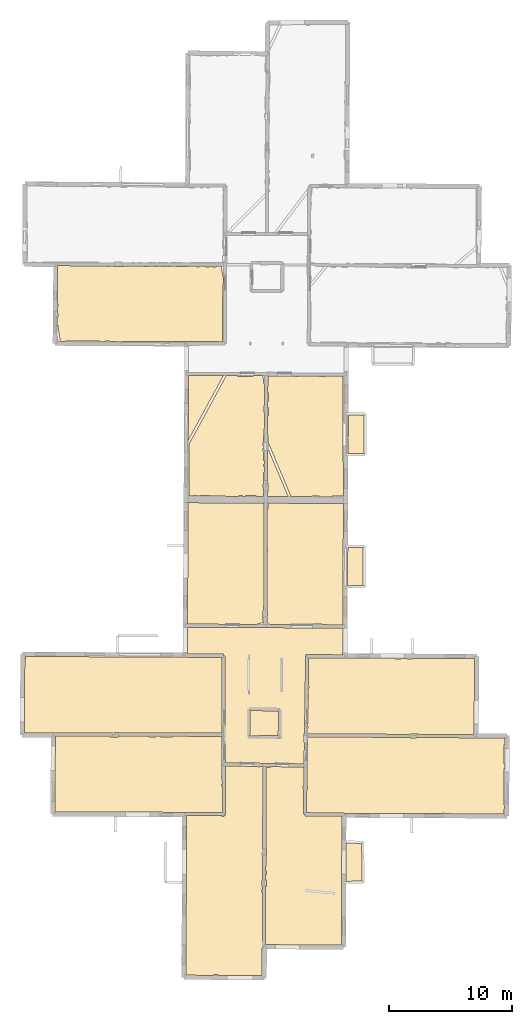
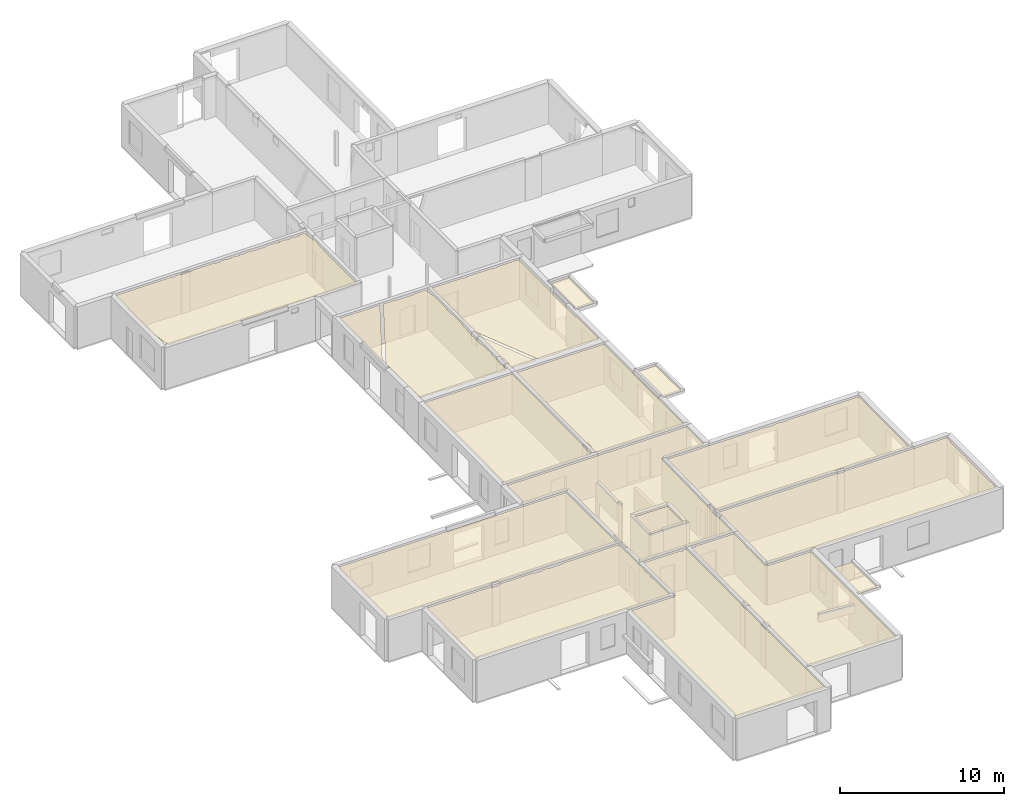
# One storey, part 12 of 15: 18 coverings.
"""IFC2X3 building model written with IfcOpenShell, lengths in metres."""

from ifc_helpers import new_model, entity, si_unit, converted_unit, derived_unit, direction, frame, origin, origin_with_axes, place, context, subcontext, project, spatial, polyline, outline, extrude, material, layer, layer_set, layer_usage, type_object, element, save


model = new_model("IFC2X3")

# Units and contexts
model_context = context("Model", 3, precision=1e-05, world=origin(), true_north=direction((0.0, 1.0)))
body_context = subcontext(model_context, "Body", "Model", "MODEL_VIEW")
ifc_project = project(units=[si_unit("LENGTHUNIT", "METRE"), si_unit("AREAUNIT", "SQUARE_METRE"), si_unit("VOLUMEUNIT", "CUBIC_METRE"), converted_unit("PLANEANGLEUNIT", "DEGREE", entity("IfcRatioMeasure", 0.0174532925199433), si_unit("PLANEANGLEUNIT", "RADIAN"), dimensions=[0, 0, 0, 0, 0, 0, 0]), si_unit("MASSUNIT", "GRAM", prefix="KILO"), derived_unit("MASSDENSITYUNIT", [(si_unit("MASSUNIT", "GRAM", prefix="KILO"), 1), (si_unit("LENGTHUNIT", "METRE"), -3)]), derived_unit("MOMENTOFINERTIAUNIT", [(si_unit("LENGTHUNIT", "METRE"), 4)]), si_unit("TIMEUNIT", "SECOND"), si_unit("FREQUENCYUNIT", "HERTZ"), si_unit("THERMODYNAMICTEMPERATUREUNIT", "DEGREE_CELSIUS"), derived_unit("THERMALTRANSMITTANCEUNIT", [(si_unit("MASSUNIT", "GRAM", prefix="KILO"), 1), (si_unit("THERMODYNAMICTEMPERATUREUNIT", "KELVIN"), -1), (si_unit("TIMEUNIT", "SECOND"), -3)]), derived_unit("VOLUMETRICFLOWRATEUNIT", [(si_unit("LENGTHUNIT", "METRE"), 3), (si_unit("TIMEUNIT", "SECOND"), -1)]), si_unit("ELECTRICCURRENTUNIT", "AMPERE"), si_unit("ELECTRICVOLTAGEUNIT", "VOLT"), si_unit("POWERUNIT", "WATT"), si_unit("FORCEUNIT", "NEWTON", prefix="KILO"), si_unit("ILLUMINANCEUNIT", "LUX"), si_unit("LUMINOUSFLUXUNIT", "LUMEN"), si_unit("LUMINOUSINTENSITYUNIT", "CANDELA"), derived_unit("USERDEFINED", [(si_unit("MASSUNIT", "GRAM", prefix="KILO"), -1), (si_unit("LENGTHUNIT", "METRE"), -2), (si_unit("TIMEUNIT", "SECOND"), 3), (si_unit("LUMINOUSFLUXUNIT", "LUMEN"), 1)]), derived_unit("LINEARVELOCITYUNIT", [(si_unit("LENGTHUNIT", "METRE"), 1), (si_unit("TIMEUNIT", "SECOND"), -1)]), si_unit("PRESSUREUNIT", "PASCAL"), derived_unit("USERDEFINED", [(si_unit("LENGTHUNIT", "METRE"), -2), (si_unit("MASSUNIT", "GRAM", prefix="KILO"), 1), (si_unit("TIMEUNIT", "SECOND"), -2)]), derived_unit("LINEARFORCEUNIT", [(si_unit("MASSUNIT", "GRAM", prefix="KILO"), 1), (si_unit("LENGTHUNIT", "METRE"), 1), (si_unit("TIMEUNIT", "SECOND"), -2), (si_unit("LENGTHUNIT", "METRE"), -1)]), derived_unit("PLANARFORCEUNIT", [(si_unit("MASSUNIT", "GRAM", prefix="KILO"), 1), (si_unit("LENGTHUNIT", "METRE"), 1), (si_unit("TIMEUNIT", "SECOND"), -2), (si_unit("LENGTHUNIT", "METRE"), -2)])], contexts=[model_context])

# Site, building, storey
placement = place(None, origin())
site = spatial("IfcSite", under=ifc_project, at=placement, CompositionType="ELEMENT")
building = spatial("IfcBuilding", under=site, at=placement, CompositionType="ELEMENT")
storey_placement = place(placement, frame((0.0, 0.0, 2.3807327747345)))
storey = spatial("IfcBuildingStorey", under=building, at=storey_placement, Name="Level 2", CompositionType="ELEMENT", Elevation=2.3807327747345)

# Coverings
ifc_material = material(Name="Covering default")
ifc_layer_1 = layer(ifc_material, 0.02)
ifc_layer_set_1 = layer_set([ifc_layer_1], Name="Covering : 20mm")
ifc_layer_usage_1 = layer_usage(ifc_layer_set_1, "AXIS3", "POSITIVE", 0.0)
covering_type_1 = type_object("IfcCoveringType", Name="Covering : 20mm", PredefinedType="CEILING")
covering_1_placement = place(placement, frame((0.0, 0.0, 5.31589412689209)))
element("IfcCovering", 1, at=covering_1_placement, inside=storey, type_object=covering_type_1, material=ifc_layer_usage_1, Name="Covering : 20mm", ObjectType="Covering : 20mm", PredefinedType="CEILING", context=body_context, shape_type="SweptSolid", body=[
    extrude(outline(polyline([(-0.157829284667969, 12.9143705368042), (2.72134494781494, 12.9002017974854), (2.719069480896, 12.8498077392578), (2.87133312225342, 12.8429336547852), (2.87508678436279, 12.9260663986206), (2.875168800354, 12.9428291320801), (3.00084209442139, 12.9432487487793), (2.98748683929443, 16.9389305114746), (5.66581439971924, 16.9010639190674), (5.66572093963623, 16.8449096679688), (5.82572078704834, 16.8446426391602), (5.82581043243408, 16.8988018035889), (6.04655170440674, 16.895679473877), (6.01854801177979, 9.86431217193604), (5.96411037445068, 9.86440277099609), (5.96385860443115, 9.71440124511719), (6.01794910430908, 9.71431159973145), (6.00982570648193, 7.67432165145874), (5.95046520233154, 7.67441987991333), (5.94960117340088, 7.15442276000977), (6.0077543258667, 7.15432596206665), (6.00651836395264, 6.8443341255188), (5.94908618927002, 6.84442901611328), (5.94883632659912, 6.69442749023438), (6.00592136383057, 6.69433259963989), (5.98218250274658, -0.08222496509552), (2.38758563995361, -0.0655936598777771), (2.38767910003662, -0.0096588134765625), (2.03768062591553, -0.00907516479492188), (2.03758907318115, -0.0639742910861969), (-0.201565742492676, -0.0536142587661743), (-0.157829284667969, 12.9143705368042)])), origin_with_axes(), (0.0, 0.0, 1.0), 0.02),
])
ifc_layer_2 = layer(ifc_material, 0.02)
ifc_layer_set_2 = layer_set([ifc_layer_2], Name="Covering : 20mm")
ifc_layer_usage_2 = layer_usage(ifc_layer_set_2, "AXIS3", "POSITIVE", 0.0)
covering_type_2 = type_object("IfcCoveringType", Name="Covering : 20mm", PredefinedType="CEILING")
covering_2_placement = place(placement, frame((0.0, 0.0, 5.31589412689209)))
element("IfcCovering", 2, at=covering_2_placement, inside=storey, type_object=covering_type_2, material=ifc_layer_usage_2, Name="Covering : 20mm", ObjectType="Covering : 20mm", PredefinedType="CEILING", context=body_context, shape_type="SweptSolid", body=[
    extrude(outline(polyline([(6.267746925354, 7.15250205993652), (6.3204984664917, 7.15250110626221), (6.32050800323486, 7.6675009727478), (6.26979923248291, 7.66750192642212), (6.27169704437256, 8.14388656616211), (6.33124828338623, 8.1437873840332), (6.33166408538818, 8.3937873840332), (6.27269268035889, 8.39388561248779), (6.27779865264893, 9.67577838897705), (6.33376216888428, 9.67535495758057), (6.33772373199463, 10.2003402709961), (6.27988910675049, 10.200777053833), (6.30630779266357, 16.8338451385498), (6.6557035446167, 16.8332633972168), (6.65579319000244, 16.8870658874512), (9.38121700286865, 16.8485336303711), (9.35917568206787, 15.328763961792), (9.30320262908936, 15.328857421875), (9.30287075042725, 15.1288566589355), (9.35627460479736, 15.1287679672241), (9.32572078704834, 13.0219354629517), (9.45070552825928, 13.0201234817505), (9.44924068450928, 12.8951320648193), (12.4550046920776, 12.8598709106445), (12.4258432388306, 2.39830803871155), (6.24891948699951, 2.42507600784302), (6.267746925354, 7.15250205993652)])), origin_with_axes(), (0.0, 0.0, 1.0), 0.02),
])
ifc_layer_3 = layer(ifc_material, 0.02)
ifc_layer_set_3 = layer_set([ifc_layer_3], Name="Covering : 20mm")
ifc_layer_usage_3 = layer_usage(ifc_layer_set_3, "AXIS3", "POSITIVE", 0.0)
covering_type_3 = type_object("IfcCoveringType", Name="Covering : 20mm", PredefinedType="CEILING")
covering_3_placement = place(placement, frame((0.0, 0.0, 5.31589412689209)))
element("IfcCovering", 3, at=covering_3_placement, inside=storey, type_object=covering_type_3, material=ifc_layer_usage_3, Name="Covering : 20mm", ObjectType="Covering : 20mm", PredefinedType="CEILING", context=body_context, shape_type="SweptSolid", body=[
    extrude(outline(polyline([(12.8089418411255, 10.684494972229), (14.0668363571167, 10.6495876312256), (14.0813512802124, 7.58163404464722), (12.8002710342407, 7.57379484176636), (12.8089418411255, 10.684494972229)])), origin_with_axes(), (0.0, 0.0, 1.0), 0.02),
])
ifc_layer_4 = layer(ifc_material, 0.02)
ifc_layer_set_4 = layer_set([ifc_layer_4], Name="Covering : 20mm")
ifc_layer_usage_4 = layer_usage(ifc_layer_set_4, "AXIS3", "POSITIVE", 0.0)
covering_type_4 = type_object("IfcCoveringType", Name="Covering : 20mm", PredefinedType="CEILING")
covering_4_placement = place(placement, frame((0.0, 0.0, 5.31589412689209)))
element("IfcCovering", 4, at=covering_4_placement, inside=storey, type_object=covering_type_4, material=ifc_layer_usage_4, Name="Covering : 20mm", ObjectType="Covering : 20mm", PredefinedType="CEILING", context=body_context, shape_type="SweptSolid", body=[
    extrude(outline(polyline([(9.60571575164795, 15.0883522033691), (9.66280460357666, 15.0882568359375), (9.66310405731201, 15.2682571411133), (9.60832500457764, 15.2683486938477), (9.65799999237061, 18.6934967041016), (9.6602201461792, 18.693452835083), (9.67202663421631, 19.3019237518311), (17.992317199707, 19.253267288208), (17.9925689697266, 19.1920928955078), (18.4975624084473, 19.194185256958), (18.4973297119141, 19.2503147125244), (23.794002532959, 19.2193412780762), (25.696964263916, 19.2175998687744), (25.6942901611328, 18.6815986633301), (25.6388053894043, 18.6816921234131), (25.6361618041992, 17.0916938781738), (25.6863632202148, 17.091609954834), (25.6846160888672, 16.7414112091064), (25.6255798339844, 16.7417087554932), (25.610652923584, 13.7817287445068), (25.6698532104492, 13.7814302444458), (25.6682586669922, 13.4616346359253), (25.6101226806641, 13.4617309570312), (25.6094207763672, 13.0385904312134), (20.8094482421875, 13.0603847503662), (20.8095474243164, 13.1197128295898), (20.6495475769043, 13.1199798583984), (20.6494483947754, 13.061110496521), (12.6366930007935, 13.0974931716919), (12.6368131637573, 13.1077556610107), (9.57751178741455, 13.1436443328857), (9.60571575164795, 15.0883522033691)])), origin_with_axes(), (0.0, 0.0, 1.0), 0.02),
])
ifc_layer_5 = layer(ifc_material, 0.02)
ifc_layer_set_5 = layer_set([ifc_layer_5], Name="Covering : 20mm")
ifc_layer_usage_5 = layer_usage(ifc_layer_set_5, "AXIS3", "POSITIVE", 0.0)
covering_type_5 = type_object("IfcCoveringType", Name="Covering : 20mm", PredefinedType="CEILING")
covering_5_placement = place(placement, frame((0.0, 0.0, 5.31589412689209)))
element("IfcCovering", 5, at=covering_5_placement, inside=storey, type_object=covering_type_5, material=ifc_layer_usage_5, Name="Covering : 20mm", ObjectType="Covering : 20mm", PredefinedType="CEILING", context=body_context, shape_type="SweptSolid", body=[
    extrude(outline(polyline([(-10.8137712478638, 19.375036239624), (-6.3936505317688, 19.3656826019287), (-6.40018844604492, 19.3149852752686), (-5.85030555725098, 19.2440700531006), (-5.84299182891846, 19.30078125), (-5.66456699371338, 19.3017635345459), (-5.66491031646729, 19.3641395568848), (-3.20010852813721, 19.358922958374), (-3.20020771026611, 19.2996635437012), (-2.69021034240723, 19.2988147735596), (-2.69011211395264, 19.3578433990479), (-2.28011035919189, 19.3569774627686), (-2.28020858764648, 19.2981338500977), (-1.32021141052246, 19.2965354919434), (-1.32011413574219, 19.354944229126), (2.72943782806396, 19.3463745117188), (2.74002361297607, 16.1797771453857), (2.68461132049561, 16.1798686981201), (2.68422794342041, 15.9498682022095), (2.7407922744751, 15.9497747421265), (2.74246311187744, 15.4497709274292), (2.6833963394165, 15.4498691558838), (2.68313121795654, 15.2898693084717), (2.74299716949463, 15.2897701263428), (2.75014972686768, 13.1500635147095), (-0.336913108825684, 13.1652555465698), (-0.336881637573242, 13.1735181808472), (-10.8434648513794, 13.213041305542), (-10.8137712478638, 19.375036239624)])), origin_with_axes(), (0.0, 0.0, 1.0), 0.02),
])
ifc_layer_6 = layer(ifc_material, 0.02)
ifc_layer_set_6 = layer_set([ifc_layer_6], Name="Covering : 20mm")
ifc_layer_usage_6 = layer_usage(ifc_layer_set_6, "AXIS3", "POSITIVE", 0.0)
covering_type_6 = type_object("IfcCoveringType", Name="Covering : 20mm", PredefinedType="CEILING")
covering_6_placement = place(placement, frame((0.0, 0.0, 5.31589412689209)))
element("IfcCovering", 6, at=covering_6_placement, inside=storey, type_object=covering_type_6, material=ifc_layer_usage_6, Name="Covering : 20mm", ObjectType="Covering : 20mm", PredefinedType="CEILING", context=body_context, shape_type="SweptSolid", body=[
    extrude(outline(polyline([(-0.0842161178588867, 28.1990261077881), (-0.26908016204834, 28.2001190185547), (12.5359716415405, 28.141284942627), (12.5263319015503, 25.9672584533691), (9.55755519866943, 25.9809303283691), (9.556960105896, 25.8517208099365), (9.51179790496826, 25.8523750305176), (9.4291524887085, 20.153902053833), (9.45167064666748, 20.1535758972168), (9.3855447769165, 19.4234485626221), (9.36744594573975, 19.4224147796631), (9.40820217132568, 18.7092838287354), (9.38498592376709, 17.1085052490234), (6.04891872406006, 17.1556720733643), (6.04891872406006, 17.1556720733643), (2.98661708831787, 17.1989669799805), (2.98159694671631, 18.7012214660645), (2.98534107208252, 18.7012538909912), (2.97933101654053, 19.3791198730469), (2.97933101654053, 19.3791160583496), (2.97933101654053, 19.3791160583496), (2.95757961273193, 25.8871517181396), (2.83257961273193, 25.8867340087891), (2.83307933807373, 26.0167293548584), (-0.0970544815063477, 26.0279636383057), (-0.0842161178588867, 28.1990261077881)])), origin_with_axes(), (0.0, 0.0, 1.0), 0.02),
])
ifc_layer_7 = layer(ifc_material, 0.02)
ifc_layer_set_7 = layer_set([ifc_layer_7], Name="Covering : 20mm")
ifc_layer_usage_7 = layer_usage(ifc_layer_set_7, "AXIS3", "POSITIVE", 0.0)
covering_type_7 = type_object("IfcCoveringType", Name="Covering : 20mm", PredefinedType="CEILING")
covering_7_placement = place(placement, frame((0.0, 0.0, 5.31589412689209)))
element("IfcCovering", 7, at=covering_7_placement, inside=storey, type_object=covering_type_7, material=ifc_layer_usage_7, Name="Covering : 20mm", ObjectType="Covering : 20mm", PredefinedType="CEILING", context=body_context, shape_type="SweptSolid", body=[
    extrude(outline(polyline([(5.00286960601807, 21.4372482299805), (7.31136417388916, 21.4050197601318), (7.28420352935791, 19.4057121276855), (5.74143886566162, 19.4234943389893), (5.74071407318115, 19.3605632781982), (4.97309970855713, 19.3699245452881), (5.00286960601807, 21.4372482299805)])), origin_with_axes(), (0.0, 0.0, 1.0), 0.02),
])
ifc_layer_8 = layer(ifc_material, 0.02)
ifc_layer_set_8 = layer_set([ifc_layer_8], Name="Covering : 20mm")
ifc_layer_usage_8 = layer_usage(ifc_layer_set_8, "AXIS3", "POSITIVE", 0.0)
covering_type_8 = type_object("IfcCoveringType", Name="Covering : 20mm", PredefinedType="CEILING")
covering_8_placement = place(placement, frame((0.0, 0.0, 5.31589412689209)))
element("IfcCovering", 8, at=covering_8_placement, inside=storey, type_object=covering_type_8, material=ifc_layer_usage_8, Name="Covering : 20mm", ObjectType="Covering : 20mm", PredefinedType="CEILING", context=body_context, shape_type="SweptSolid", body=[
    extrude(outline(polyline([(9.68848323822021, 20.1500949859619), (9.67912578582764, 20.150276184082), (9.71303272247314, 22.4881858825684), (9.76511287689209, 22.4881000518799), (9.76537990570068, 22.648099899292), (9.71535396575928, 22.6481838226318), (9.72434520721436, 23.2681694030762), (9.77641201019287, 23.2680816650391), (9.77665996551514, 23.418083190918), (9.72651958465576, 23.4181671142578), (9.75990390777588, 25.7199974060059), (12.7101545333862, 25.7064094543457), (12.7101736068726, 25.7107200622559), (16.7904472351074, 25.6900615692139), (16.7903594970703, 25.636417388916), (17.2603607177734, 25.6356353759766), (17.2604446411133, 25.6876811981201), (17.7318840026855, 25.6852951049805), (17.7303581237793, 25.6348552703857), (18.194881439209, 25.6208057403564), (18.1967582702637, 25.6829414367676), (23.2262382507324, 25.6574764251709), (23.1918487548828, 19.4728660583496), (18.6801567077637, 19.4992504119873), (18.6802444458008, 19.5532646179199), (17.9602470397949, 19.5544605255127), (17.9601631164551, 19.5034599304199), (9.67687702178955, 19.5518989562988), (9.68848323822021, 20.1500949859619)])), origin_with_axes(), (0.0, 0.0, 1.0), 0.02),
])
ifc_layer_9 = layer(ifc_material, 0.02)
ifc_layer_set_9 = layer_set([ifc_layer_9], Name="Covering : 20mm")
ifc_layer_usage_9 = layer_usage(ifc_layer_set_9, "AXIS3", "POSITIVE", 0.0)
covering_type_9 = type_object("IfcCoveringType", Name="Covering : 20mm", PredefinedType="CEILING")
covering_9_placement = place(placement, frame((0.0, 0.0, 5.31589412689209)))
element("IfcCovering", 9, at=covering_9_placement, inside=storey, type_object=covering_type_9, material=ifc_layer_usage_9, Name="Covering : 20mm", ObjectType="Covering : 20mm", PredefinedType="CEILING", context=body_context, shape_type="SweptSolid", body=[
    extrude(outline(polyline([(-13.2942066192627, 25.5564613342285), (-13.2398147583008, 25.5563697814941), (-13.2393636703491, 25.8281078338623), (-0.283282279968262, 25.7785091400146), (-0.283320426940918, 25.7686748504639), (-0.283320426940918, 25.7686748504639), (-0.283320426940918, 25.7686748504639), (2.70801258087158, 25.7572059631348), (2.72860431671143, 19.596378326416), (-5.64968967437744, 19.6141090393066), (-5.64959049224854, 19.6737365722656), (-6.05958938598633, 19.6744174957275), (-6.05968809127808, 19.6149768829346), (-10.9929056167603, 19.625415802002), (-10.9929227828979, 19.6171932220459), (-13.3224763870239, 19.6259212493896), (-13.2942066192627, 25.5564613342285)])), origin_with_axes(), (0.0, 0.0, 1.0), 0.02),
])
ifc_layer_10 = layer(ifc_material, 0.02)
ifc_layer_set_10 = layer_set([ifc_layer_10], Name="Covering : 20mm")
ifc_layer_usage_10 = layer_usage(ifc_layer_set_10, "AXIS3", "POSITIVE", 0.0)
covering_type_10 = type_object("IfcCoveringType", Name="Covering : 20mm", PredefinedType="CEILING")
covering_10_placement = place(placement, frame((0.0, 0.0, 5.31589412689209)))
element("IfcCovering", 10, at=covering_10_placement, inside=storey, type_object=covering_type_10, material=ifc_layer_usage_10, Name="Covering : 20mm", ObjectType="Covering : 20mm", PredefinedType="CEILING", context=body_context, shape_type="SweptSolid", body=[
    extrude(outline(polyline([(6.35837268829346, 29.1037788391113), (6.41611194610596, 29.1036815643311), (6.41689395904541, 29.5736770629883), (6.36034107208252, 29.5737705230713), (6.38044452667236, 34.3737449645996), (6.4348783493042, 34.3736534118652), (6.43539333343506, 34.6836547851562), (6.38174343109131, 34.6837425231934), (6.3948278427124, 37.8077087402344), (6.45058345794678, 37.8036346435547), (6.48562908172607, 38.2830352783203), (12.5807867050171, 38.2485466003418), (12.5371236801147, 28.4012813568115), (10.8549642562866, 28.4090099334717), (10.8550596237183, 28.4662952423096), (9.96506023406982, 28.4677753448486), (9.96496868133545, 28.4130992889404), (6.60980129241943, 28.4285144805908), (6.35644435882568, 28.6436157226562), (6.35837268829346, 29.1037788391113)])), origin_with_axes(), (0.0, 0.0, 1.0), 0.02),
])
ifc_layer_11 = layer(ifc_material, 0.02)
ifc_layer_set_11 = layer_set([ifc_layer_11], Name="Covering : 20mm")
ifc_layer_usage_11 = layer_usage(ifc_layer_set_11, "AXIS3", "POSITIVE", 0.0)
covering_type_11 = type_object("IfcCoveringType", Name="Covering : 20mm", PredefinedType="CEILING")
covering_11_placement = place(placement, frame((0.0, 0.0, 5.31589412689209)))
element("IfcCovering", 11, at=covering_11_placement, inside=storey, type_object=covering_type_11, material=ifc_layer_usage_11, Name="Covering : 20mm", ObjectType="Covering : 20mm", PredefinedType="CEILING", context=body_context, shape_type="SweptSolid", body=[
    extrude(outline(polyline([(-0.0243721008300781, 38.3198699951172), (6.14682483673096, 38.2849540710449), (6.11038303375244, 29.5841903686523), (6.05691242218018, 29.5842781066895), (6.05541324615479, 28.6832809448242), (6.10661029815674, 28.6831951141357), (6.10625553131104, 28.5987606048584), (5.52420139312744, 28.4335021972656), (-0.082676887512207, 28.459264755249), (-0.0243721008300781, 38.3198699951172)])), origin_with_axes(), (0.0, 0.0, 1.0), 0.02),
])
ifc_layer_12 = layer(ifc_material, 0.02)
ifc_layer_set_12 = layer_set([ifc_layer_12], Name="Covering : 20mm")
ifc_layer_usage_12 = layer_usage(ifc_layer_set_12, "AXIS3", "POSITIVE", 0.0)
covering_type_12 = type_object("IfcCoveringType", Name="Covering : 20mm", PredefinedType="CEILING")
covering_12_placement = place(placement, frame((0.0, 0.0, 5.31589412689209)))
element("IfcCovering", 12, at=covering_12_placement, inside=storey, type_object=covering_type_12, material=ifc_layer_usage_12, Name="Covering : 20mm", ObjectType="Covering : 20mm", PredefinedType="CEILING", context=body_context, shape_type="SweptSolid", body=[
    extrude(outline(polyline([(12.935019493103, 34.6919975280762), (14.1611585617065, 34.6966934204102), (14.1830930709839, 31.5818977355957), (12.9211854934692, 31.5717544555664), (12.935019493103, 34.6919975280762)])), origin_with_axes(), (0.0, 0.0, 1.0), 0.02),
])
ifc_layer_13 = layer(ifc_material, 0.02)
ifc_layer_set_13 = layer_set([ifc_layer_13], Name="Covering : 20mm")
ifc_layer_usage_13 = layer_usage(ifc_layer_set_13, "AXIS3", "POSITIVE", 0.0)
covering_type_13 = type_object("IfcCoveringType", Name="Covering : 20mm", PredefinedType="CEILING")
covering_13_placement = place(placement, frame((0.0, 0.0, 5.31589412689209)))
element("IfcCovering", 13, at=covering_13_placement, inside=storey, type_object=covering_type_13, material=ifc_layer_usage_13, Name="Covering : 20mm", ObjectType="Covering : 20mm", PredefinedType="CEILING", context=body_context, shape_type="SweptSolid", body=[
    extrude(outline(polyline([(6.42664432525635, 45.4036865234375), (6.48322582244873, 45.4035911560059), (6.48427486419678, 46.0335922241211), (6.42928218841553, 46.0336837768555), (6.43133449554443, 46.5236778259277), (6.48508930206299, 46.5235900878906), (6.48625469207764, 47.2235908508301), (6.43426609039307, 47.2236785888672), (6.44015216827393, 48.628734588623), (8.63857555389404, 48.6177749633789), (8.6384801864624, 48.5600090026855), (8.94847774505615, 48.5594940185547), (8.94857120513916, 48.6162261962891), (10.6097536087036, 48.6079444885254), (10.6084775924683, 48.5567321777344), (11.0384588241577, 48.5460205078125), (11.0399484634399, 48.6058006286621), (12.5485486984253, 48.5982780456543), (12.5369634628296, 41.6335144042969), (12.5957956314087, 41.633415222168), (12.5834245681763, 38.8434371948242), (11.6623239517212, 38.8449668884277), (11.6622381210327, 38.7937507629395), (10.6422452926636, 38.7995223999023), (10.6423406600952, 38.8566627502441), (10.0323438644409, 38.8576774597168), (10.0322523117065, 38.8029747009277), (8.32680988311768, 38.8126258850098), (6.46958446502686, 43.2136116027832), (6.47059917449951, 43.8236083984375), (6.42002582550049, 43.8236923217773), (6.42664432525635, 45.4036865234375)])), origin_with_axes(), (0.0, 0.0, 1.0), 0.02),
])
ifc_layer_14 = layer(ifc_material, 0.02)
ifc_layer_set_14 = layer_set([ifc_layer_14], Name="Covering : 20mm")
ifc_layer_usage_14 = layer_usage(ifc_layer_set_14, "AXIS3", "POSITIVE", 0.0)
covering_type_14 = type_object("IfcCoveringType", Name="Covering : 20mm", PredefinedType="CEILING")
covering_14_placement = place(placement, frame((0.0, 0.0, 5.31589412689209)))
element("IfcCovering", 14, at=covering_14_placement, inside=storey, type_object=covering_type_14, material=ifc_layer_usage_14, Name="Covering : 20mm", ObjectType="Covering : 20mm", PredefinedType="CEILING", context=body_context, shape_type="SweptSolid", body=[
    extrude(outline(polyline([(6.40666103363037, 38.8234939575195), (8.10921192169189, 38.8138580322266), (6.41584873199463, 42.8265419006348), (6.40347957611084, 39.8732566833496), (6.47025203704834, 39.8734703063965), (6.47227573394775, 39.2384719848633), (6.4008207321167, 39.2382431030273), (6.40666103363037, 38.8234939575195)])), origin_with_axes(), (0.0, 0.0, 1.0), 0.02),
])
ifc_layer_15 = layer(ifc_material, 0.02)
ifc_layer_set_15 = layer_set([ifc_layer_15], Name="Covering : 20mm")
ifc_layer_usage_15 = layer_usage(ifc_layer_set_15, "AXIS3", "POSITIVE", 0.0)
covering_type_15 = type_object("IfcCoveringType", Name="Covering : 20mm", PredefinedType="CEILING")
covering_15_placement = place(placement, frame((0.0, 0.0, 5.31589412689209)))
element("IfcCovering", 15, at=covering_15_placement, inside=storey, type_object=covering_type_15, material=ifc_layer_usage_15, Name="Covering : 20mm", ObjectType="Covering : 20mm", PredefinedType="CEILING", context=body_context, shape_type="SweptSolid", body=[
    extrude(outline(polyline([(0.0527372360229492, 38.8594436645508), (0.41232967376709, 38.8574104309082), (0.412423133850098, 38.9136810302734), (0.642422676086426, 38.9132995605469), (0.642327308654785, 38.8561096191406), (0.921595573425293, 38.8545303344727), (0.922420501708984, 38.9128341674805), (1.72240352630615, 38.9015007019043), (1.7216739654541, 38.8500022888184), (4.11229801177979, 38.8364753723145), (4.11238384246826, 38.8875274658203), (4.38238430023193, 38.887077331543), (4.38229656219482, 38.8349494934082), (4.64229488372803, 38.8334770202637), (4.64238262176514, 38.8866424560547), (5.48238277435303, 38.8852462768555), (5.48228931427002, 38.8287239074707), (6.09228229522705, 38.8252716064453), (6.09279537200928, 39.1342315673828), (6.15038204193115, 39.1341361999512), (6.15082454681396, 39.2398948669434), (6.10082530975342, 39.240104675293), (6.10214138031006, 39.5542144775391), (6.04349613189697, 39.554313659668), (6.04397869110107, 39.8443145751953), (6.10335636138916, 39.8442153930664), (6.10438823699951, 40.0905151367188), (6.10550785064697, 40.7642135620117), (6.15720844268799, 40.7641296386719), (6.15926074981689, 41.2541236877441), (6.10632228851318, 41.2542114257812), (6.10660648345947, 41.4242134094238), (6.15997409820557, 41.4241256713867), (6.16128253936768, 41.7368545532227), (6.10712146759033, 41.7342109680176), (6.0587682723999, 42.724292755127), (6.116379737854, 42.7271041870117), (6.11906147003174, 42.9513397216797), (6.0591516494751, 42.9542922973633), (6.09194087982178, 43.6195373535156), (6.11025524139404, 43.6186332702637), (6.12146282196045, 44.3441925048828), (6.17220401763916, 44.344108581543), (6.177565574646, 45.6240997314453), (6.12359142303467, 45.6241912841797), (6.12459087371826, 46.2241897583008), (6.18007946014404, 46.2240982055664), (6.18731021881104, 47.9507369995117), (6.12745189666748, 47.9441871643066), (6.05233097076416, 48.6306686401367), (5.21907329559326, 48.634822845459), (5.21850109100342, 48.5756988525391), (3.96851825714111, 48.587776184082), (3.96903324127197, 48.6410522460938), (3.06908321380615, 48.6455421447754), (0.0287237167358398, 43.0532493591309), (0.0527372360229492, 38.8594436645508)])), origin_with_axes(), (0.0, 0.0, 1.0), 0.02),
])
ifc_layer_16 = layer(ifc_material, 0.02)
ifc_layer_set_16 = layer_set([ifc_layer_16], Name="Covering : 20mm")
ifc_layer_usage_16 = layer_usage(ifc_layer_set_16, "AXIS3", "POSITIVE", 0.0)
covering_type_16 = type_object("IfcCoveringType", Name="Covering : 20mm", PredefinedType="CEILING")
covering_16_placement = place(placement, frame((0.0, 0.0, 5.31589412689209)))
element("IfcCovering", 16, at=covering_16_placement, inside=storey, type_object=covering_type_16, material=ifc_layer_usage_16, Name="Covering : 20mm", ObjectType="Covering : 20mm", PredefinedType="CEILING", context=body_context, shape_type="SweptSolid", body=[
    extrude(outline(polyline([(12.9714632034302, 42.910816192627), (12.9706106185913, 42.9108200073242), (12.9826192855835, 45.4276390075684), (14.2439489364624, 45.4324340820312), (14.2426176071167, 42.3172416687012), (12.9689054489136, 42.3339233398438), (12.9714632034302, 42.910816192627)])), origin_with_axes(), (0.0, 0.0, 1.0), 0.02),
])
ifc_layer_17 = layer(ifc_material, 0.02)
ifc_layer_set_17 = layer_set([ifc_layer_17], Name="Covering : 20mm")
ifc_layer_usage_17 = layer_usage(ifc_layer_set_17, "AXIS3", "POSITIVE", 0.0)
covering_type_17 = type_object("IfcCoveringType", Name="Covering : 20mm", PredefinedType="CEILING")
covering_17_placement = place(placement, frame((0.0, 0.0, 5.31589412689209)))
element("IfcCovering", 17, at=covering_17_placement, inside=storey, type_object=covering_type_17, material=ifc_layer_usage_17, Name="Covering : 20mm", ObjectType="Covering : 20mm", PredefinedType="CEILING", context=body_context, shape_type="SweptSolid", body=[
    extrude(outline(polyline([(0.00677490234375, 48.6608085632324), (2.84205150604248, 48.646671295166), (-0.0244855880737305, 43.3740997314453), (0.00677490234375, 48.6608085632324)])), origin_with_axes(), (0.0, 0.0, 1.0), 0.02),
])
ifc_layer_18 = layer(ifc_material, 0.02)
ifc_layer_set_18 = layer_set([ifc_layer_18], Name="Covering : 20mm")
ifc_layer_usage_18 = layer_usage(ifc_layer_set_18, "AXIS3", "POSITIVE", 0.0)
covering_type_18 = type_object("IfcCoveringType", Name="Covering : 20mm", PredefinedType="CEILING")
covering_18_placement = place(placement, frame((0.0, 0.0, 5.31589412689209)))
element("IfcCovering", 18, at=covering_18_placement, inside=storey, type_object=covering_type_18, material=ifc_layer_usage_18, Name="Covering : 20mm", ObjectType="Covering : 20mm", PredefinedType="CEILING", context=body_context, shape_type="SweptSolid", body=[
    extrude(outline(polyline([(-10.6589193344116, 53.4121170043945), (-10.6034755706787, 53.4120254516602), (-10.6029758453369, 53.7120246887207), (-10.6561870574951, 53.7121124267578), (-10.6510877609253, 54.2721061706543), (-10.5920467376709, 54.2720069885254), (-10.5917472839355, 54.4520072937012), (-10.6494483947754, 54.4521026611328), (-10.6211013793945, 57.5648040771484), (-6.62658309936523, 57.5533905029297), (-6.62668037414551, 57.4954147338867), (-6.42667961120605, 57.4950790405273), (-6.42658281326294, 57.5528182983398), (-6.00658226013184, 57.5516166687012), (-6.00667858123779, 57.494384765625), (-5.24668121337891, 57.4931182861328), (-5.2465877532959, 57.549446105957), (-3.6365909576416, 57.5448455810547), (-3.63668251037598, 57.4904403686523), (-3.25668430328369, 57.4898071289062), (-3.25659465789795, 57.5437622070312), (-2.81659507751465, 57.5425033569336), (-2.81668376922607, 57.4890747070312), (-2.56668472290039, 57.4886627197266), (-2.56659698486328, 57.5417900085449), (-2.11659908294678, 57.5405044555664), (-2.11668586730957, 57.4879112243652), (-1.92668628692627, 57.4875946044922), (-1.92659854888916, 57.5399589538574), (-1.72659873962402, 57.5393905639648), (-1.72668552398682, 57.4872627258301), (-1.44668674468994, 57.4867973327637), (-1.44660091400146, 57.5385894775391), (-1.02660274505615, 57.5373878479004), (-1.02668762207031, 57.4860992431641), (-0.0366888046264648, 57.4844512939453), (-0.0366058349609375, 57.5345611572266), (0.693394660949707, 57.5324745178223), (0.693295478820801, 57.4732398986816), (0.873293876647949, 57.4729385375977), (0.873393058776855, 57.5319595336914), (1.3633918762207, 57.5305595397949), (1.36329460144043, 57.4721260070801), (1.69329357147217, 57.4715766906738), (1.69339084625244, 57.5296173095703), (1.96338844299316, 57.5288467407227), (1.96329212188721, 57.4711265563965), (2.25329303741455, 57.4706420898438), (2.25338840484619, 57.528018951416), (2.66506099700928, 57.5268402099609), (2.79192638397217, 56.6497459411621), (2.84982967376709, 56.6581192016602), (2.84705829620361, 56.1392974853516), (2.7910795211792, 56.1397476196289), (2.752760887146, 51.3613510131836), (2.42312908172607, 51.3603515625), (2.42321300506592, 51.4103546142578), (-5.36677837371826, 51.4233093261719), (-5.36686992645264, 51.3681869506836), (-5.84742641448975, 51.3708610534668), (-5.84677696228027, 51.4241104125977), (-6.79676055908203, 51.4356880187988), (-6.79748630523682, 51.3761520385742), (-7.21706199645996, 51.3784866333008), (-7.21675777435303, 51.4363861083984), (-9.99674034118652, 51.4510116577148), (-9.99704074859619, 51.3939628601074), (-10.407886505127, 51.3962516784668), (-10.6146755218506, 52.6920394897461), (-10.6655511856079, 52.6839218139648), (-10.6589193344116, 53.4121170043945)])), origin_with_axes(), (0.0, 0.0, 1.0), 0.02),
])

save(model, "model.ifc")
